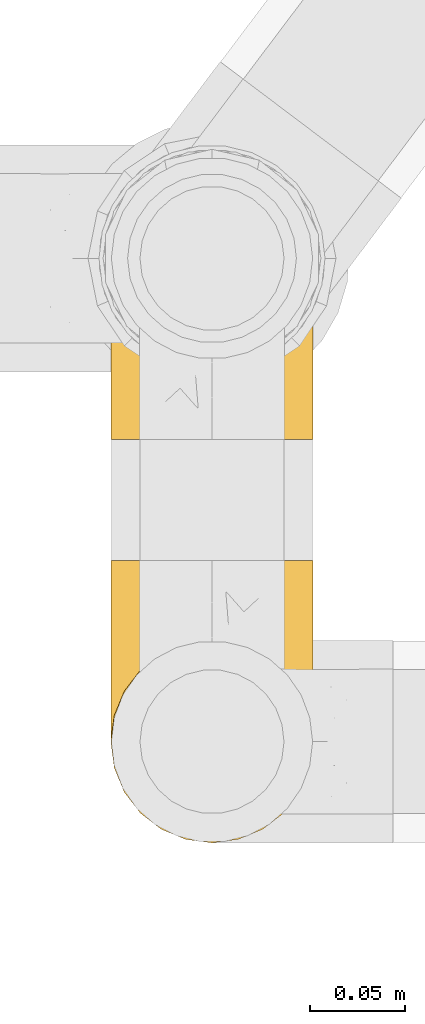
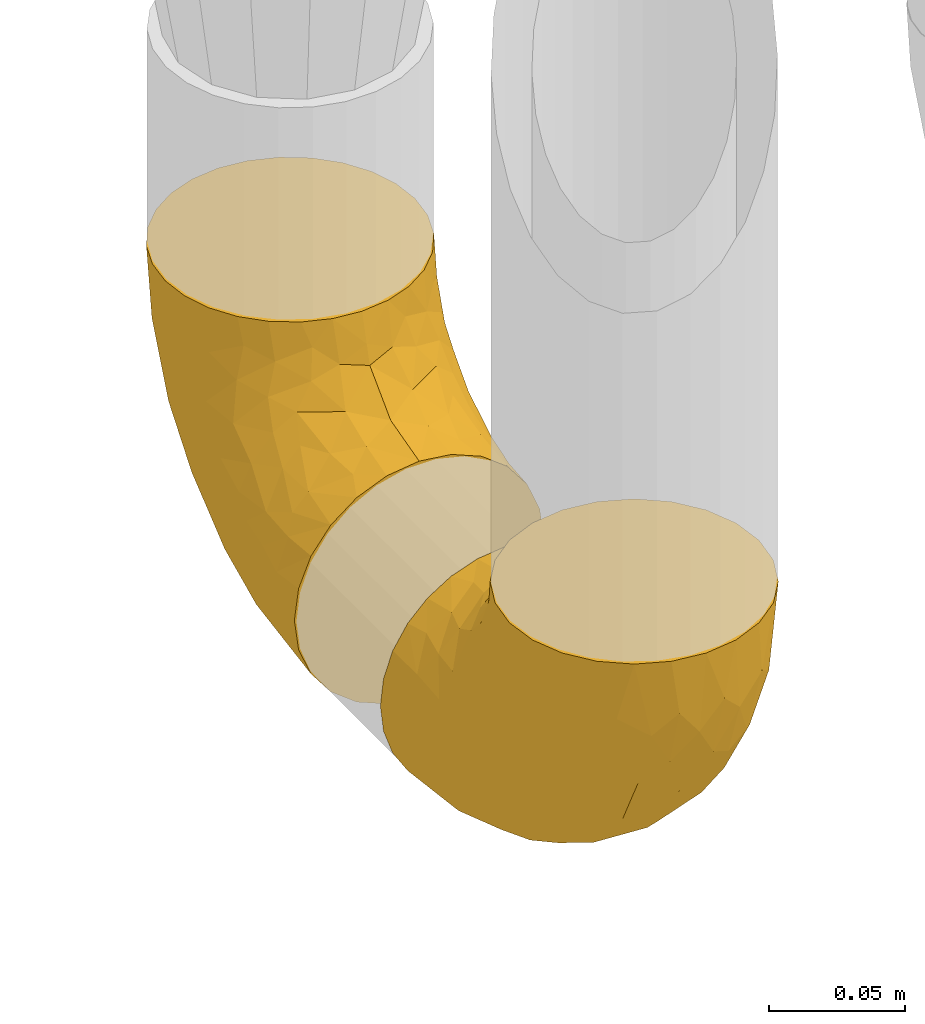
# One storey, part 377 of 827: 2 coverings.
"""IFC2X3 building model written with IfcOpenShell, lengths in millimetres."""

from ifc_helpers import new_model, entity, si_unit, converted_unit, derived_unit, direction, frame, origin, place, context, subcontext, project, spatial, faceted_brep, element, save


model = new_model("IFC2X3")

# Units and contexts
model_context = context("Model", 3, precision=0.01, world=origin(), true_north=direction((6.12303176911189e-17, 1.0)))
body_context = subcontext(model_context, "Body", "Model", "MODEL_VIEW")
ifc_project = project(units=[si_unit("LENGTHUNIT", "METRE", prefix="MILLI"), si_unit("AREAUNIT", "SQUARE_METRE"), si_unit("VOLUMEUNIT", "CUBIC_METRE"), converted_unit("PLANEANGLEUNIT", "DEGREE", entity("IfcRatioMeasure", 0.0174532925199433), si_unit("PLANEANGLEUNIT", "RADIAN"), dimensions=[0, 0, 0, 0, 0, 0, 0]), si_unit("MASSUNIT", "GRAM", prefix="KILO"), derived_unit("MASSDENSITYUNIT", [(si_unit("MASSUNIT", "GRAM", prefix="KILO"), 1), (si_unit("LENGTHUNIT", "METRE"), -3)]), derived_unit("MOMENTOFINERTIAUNIT", [(si_unit("LENGTHUNIT", "METRE"), 4)]), si_unit("TIMEUNIT", "SECOND"), si_unit("FREQUENCYUNIT", "HERTZ"), si_unit("THERMODYNAMICTEMPERATUREUNIT", "DEGREE_CELSIUS"), derived_unit("THERMALTRANSMITTANCEUNIT", [(si_unit("MASSUNIT", "GRAM", prefix="KILO"), 1), (si_unit("THERMODYNAMICTEMPERATUREUNIT", "KELVIN"), -1), (si_unit("TIMEUNIT", "SECOND"), -3)]), derived_unit("VOLUMETRICFLOWRATEUNIT", [(si_unit("LENGTHUNIT", "METRE"), 3), (si_unit("TIMEUNIT", "SECOND"), -1)]), derived_unit("MASSFLOWRATEUNIT", [(si_unit("MASSUNIT", "GRAM", prefix="KILO"), 1), (si_unit("TIMEUNIT", "SECOND"), -1)]), derived_unit("ROTATIONALFREQUENCYUNIT", [(si_unit("TIMEUNIT", "SECOND"), -1)]), si_unit("ELECTRICCURRENTUNIT", "AMPERE"), si_unit("ELECTRICVOLTAGEUNIT", "VOLT"), si_unit("POWERUNIT", "WATT"), si_unit("FORCEUNIT", "NEWTON", prefix="KILO"), si_unit("ILLUMINANCEUNIT", "LUX"), si_unit("LUMINOUSFLUXUNIT", "LUMEN"), si_unit("LUMINOUSINTENSITYUNIT", "CANDELA"), derived_unit("USERDEFINED", [(si_unit("MASSUNIT", "GRAM", prefix="KILO"), -1), (si_unit("LENGTHUNIT", "METRE"), -2), (si_unit("TIMEUNIT", "SECOND"), 3), (si_unit("LUMINOUSFLUXUNIT", "LUMEN"), 1)]), derived_unit("LINEARVELOCITYUNIT", [(si_unit("LENGTHUNIT", "METRE"), 1), (si_unit("TIMEUNIT", "SECOND"), -1)]), si_unit("PRESSUREUNIT", "PASCAL"), derived_unit("USERDEFINED", [(si_unit("LENGTHUNIT", "METRE"), -2), (si_unit("MASSUNIT", "GRAM", prefix="KILO"), 1), (si_unit("TIMEUNIT", "SECOND"), -2)]), derived_unit("LINEARFORCEUNIT", [(si_unit("MASSUNIT", "GRAM", prefix="KILO"), 1), (si_unit("LENGTHUNIT", "METRE"), 1), (si_unit("TIMEUNIT", "SECOND"), -2), (si_unit("LENGTHUNIT", "METRE"), -1)]), derived_unit("PLANARFORCEUNIT", [(si_unit("MASSUNIT", "GRAM", prefix="KILO"), 1), (si_unit("LENGTHUNIT", "METRE"), 1), (si_unit("TIMEUNIT", "SECOND"), -2), (si_unit("LENGTHUNIT", "METRE"), -2)])], contexts=[model_context])

# Site, building, storey
site_placement = place(None, origin())
site = spatial("IfcSite", under=ifc_project, at=site_placement, CompositionType="ELEMENT")
building_placement = place(site_placement, origin())
building = spatial("IfcBuilding", under=site, at=building_placement, CompositionType="ELEMENT")
storey_placement = place(building_placement, frame((0.0, 0.0, 28200.0)))
storey = spatial("IfcBuildingStorey", under=building, at=storey_placement, Name="08", CompositionType="ELEMENT", Elevation=28200.0)

# Coverings
covering_1_placement = place(storey_placement, frame((45438.63, 13582.19, 295.35)))
element("IfcCovering", 1, at=covering_1_placement, inside=storey, Name=":ADSK_", ObjectType=":ADSK_", PredefinedType="INSULATION", context=body_context, shape_type="Brep", body=[
    faceted_brep([(66.44, 149.65, 2.92), (54.65, 149.65, 1.6), (42.84, 149.65, 2.93), (31.62, 149.65, 6.85), (21.56, 149.65, 13.18), (13.16, 149.65, 21.58), (6.84, 149.65, 31.64), (2.92, 149.65, 42.85), (1.6, 149.65, 54.65), (2.93, 149.65, 66.46), (6.85, 149.65, 77.67), (13.18, 149.65, 87.73), (21.58, 149.65, 96.13), (31.64, 149.65, 102.45), (42.85, 149.65, 106.37), (54.65, 149.65, 107.7), (66.46, 149.65, 106.36), (77.67, 149.65, 102.44), (87.73, 149.65, 96.11), (96.13, 149.65, 87.71), (102.45, 149.65, 77.65), (106.37, 149.65, 66.44), (107.7, 149.65, 54.65), (106.36, 149.65, 42.84), (102.44, 149.65, 31.62), (96.11, 149.65, 21.56), (87.71, 149.65, 13.16), (77.65, 149.65, 6.84), (40.91, 105.89, 149.65), (28.12, 100.59, 149.65), (17.13, 92.16, 149.65), (8.7, 81.17, 149.65), (3.4, 68.38, 149.65), (1.6, 54.65, 149.65), (3.4, 40.91, 149.65), (8.7, 28.12, 149.65), (17.13, 17.13, 149.65), (28.12, 8.7, 149.65), (40.91, 3.4, 149.65), (54.65, 1.6, 149.65), (68.38, 3.4, 149.65), (81.17, 8.7, 149.65), (92.16, 17.13, 149.65), (100.59, 28.12, 149.65), (105.89, 40.91, 149.65), (107.7, 54.65, 149.65), (105.89, 68.38, 149.65), (100.59, 81.17, 149.65), (92.16, 92.16, 149.65), (81.17, 100.59, 149.65), (68.38, 105.89, 149.65), (54.65, 107.7, 149.65), (85.53, 14.05, 123.27), (73.42, 9.45, 114.15), (83.77, 22.36, 92.97), (64.22, 4.7, 124.11), (54.65, 6.64, 111.33), (96.72, 81.47, 42.13), (93.36, 56.83, 56.83), (84.47, 64.02, 40.31), (71.37, 34.04, 61.55), (54.65, 21.43, 75.62), (54.65, 44.96, 44.96), (103.47, 49.8, 91.12), (100.91, 35.43, 109.83), (99.1, 42.1, 88.02), (105.43, 43.59, 119.19), (106.79, 57.88, 99.11), (89.81, 91.8, 27.97), (79.59, 88.01, 21.92), (81.29, 115.65, 12.94), (74.01, 18.94, 88.29), (64.14, 12.83, 95.35), (94.75, 24.96, 113.84), (54.65, 111.33, 6.64), (70.74, 113.8, 8.58), (68.3, 60.89, 33.39), (66.05, 86.24, 17.23), (100.73, 65.84, 61.99), (106.78, 124.58, 47.9), (103.6, 121.36, 37.72), (107.7, 72.79, 93.81), (107.7, 66.04, 107.05), (107.7, 59.29, 120.29), (106.07, 73.26, 73.26), (90.59, 121.69, 18.58), (97.43, 109.82, 29.72), (84.51, 40.11, 64.31), (93.3, 36.57, 82.84), (107.7, 93.81, 72.79), (107.7, 83.3, 83.3), (107.7, 136.6, 56.71), (107.7, 120.29, 59.29), (106.79, 99.11, 57.88), (107.7, 107.05, 66.04), (103.47, 91.12, 49.8), (54.65, 75.62, 21.43), (107.7, 56.97, 134.97), (76.99, 126.65, 108.79), (84.28, 116.55, 110.84), (91.11, 120.09, 101.53), (106.26, 76.06, 111.84), (102.6, 83.69, 119.98), (106.08, 71.88, 123.54), (106.56, 66.92, 134.54), (105.36, 110.43, 80.57), (106.74, 121.31, 69.55), (101.59, 81.0, 134.56), (54.65, 113.32, 128.67), (54.65, 111.09, 136.98), (67.71, 109.14, 133.56), (91.36, 95.86, 131.66), (94.33, 99.07, 117.75), (87.1, 106.92, 118.23), (65.84, 131.39, 110.55), (54.65, 136.98, 111.09), (54.65, 128.67, 113.32), (68.92, 117.07, 120.2), (100.82, 96.39, 105.95), (79.83, 106.61, 127.69), (77.13, 103.72, 139.88), (105.9, 92.14, 92.14), (101.53, 107.13, 93.82), (106.72, 98.03, 82.28), (97.75, 88.38, 130.86), (103.08, 130.66, 78.78), (106.39, 135.45, 67.58), (98.1, 123.57, 90.58), (95.02, 137.75, 90.23), (86.9, 133.2, 99.39), (74.42, 138.8, 105.17), (54.65, 120.99, 120.99), (105.28, 84.53, 104.59), (92.87, 108.72, 108.24), (17.93, 95.86, 131.66), (6.22, 130.67, 78.8), (41.58, 109.13, 133.57), (1.6, 93.81, 72.79), (2.57, 98.02, 82.27), (3.94, 110.43, 80.59), (43.46, 131.4, 110.55), (32.32, 126.66, 108.79), (40.38, 117.08, 120.2), (16.44, 108.74, 108.25), (8.47, 96.31, 106.06), (15.01, 99.11, 117.78), (11.21, 123.58, 90.6), (7.78, 107.12, 93.87), (1.6, 72.79, 93.81), (1.6, 66.04, 107.05), (3.04, 76.07, 111.89), (1.6, 56.97, 134.97), (2.73, 66.92, 134.54), (1.6, 120.29, 59.29), (1.6, 107.05, 66.04), (2.55, 121.26, 69.56), (3.98, 84.46, 104.56), (6.69, 83.69, 119.98), (7.7, 81.0, 134.56), (3.21, 71.88, 123.54), (14.28, 137.76, 90.25), (22.42, 133.21, 99.4), (25.02, 116.58, 110.83), (18.18, 120.1, 101.52), (34.89, 138.81, 105.18), (1.6, 136.6, 56.71), (32.17, 103.72, 139.89), (22.23, 106.96, 118.22), (2.91, 135.44, 67.6), (11.54, 88.38, 130.86), (1.6, 83.3, 83.3), (3.38, 92.12, 92.12), (29.46, 106.6, 127.71), (1.6, 59.29, 120.29), (25.52, 22.36, 92.97), (23.76, 14.05, 123.27), (14.54, 24.96, 113.84), (8.38, 35.43, 109.83), (45.07, 4.71, 124.03), (35.87, 9.45, 114.15), (45.14, 11.79, 98.04), (2.5, 57.88, 99.11), (2.51, 124.57, 47.9), (5.68, 121.37, 37.74), (5.82, 91.12, 49.8), (15.93, 56.83, 56.83), (12.54, 81.48, 42.16), (24.81, 64.05, 40.3), (2.5, 99.11, 57.88), (3.22, 73.26, 73.26), (3.86, 43.59, 119.19), (35.85, 19.5, 86.61), (19.47, 91.8, 27.99), (18.68, 121.7, 18.59), (29.68, 88.04, 21.92), (27.95, 123.34, 11.28), (40.99, 60.89, 33.39), (37.92, 34.04, 61.55), (11.85, 109.85, 29.73), (10.19, 42.1, 88.01), (8.55, 65.78, 62.08), (38.53, 113.81, 8.58), (15.99, 36.57, 82.84), (24.79, 40.12, 64.3), (5.82, 49.8, 91.12), (40.56, 86.08, 18.05)], [[[0, 1, 2, 3, 4, 5, 6, 7, 8, 9, 10, 11, 12, 13, 14, 15, 16, 17, 18, 19, 20, 21, 22, 23, 24, 25, 26, 27]], [[28, 29, 30, 31, 32, 33, 34, 35, 36, 37, 38, 39, 40, 41, 42, 43, 44, 45, 46, 47, 48, 49, 50, 51]], [[52, 53, 54]], [[55, 39, 56]], [[57, 58, 59]], [[60, 61, 62]], [[63, 64, 65]], [[66, 63, 67]], [[68, 69, 70]], [[53, 71, 54]], [[41, 40, 53]], [[53, 72, 71]], [[73, 42, 52]], [[42, 41, 52]], [[74, 0, 75]], [[69, 76, 77]], [[43, 73, 64]], [[45, 44, 66]], [[57, 78, 58]], [[23, 79, 80]], [[67, 81, 82, 83]], [[67, 84, 81]], [[24, 23, 80]], [[25, 85, 26]], [[86, 85, 25]], [[42, 73, 43]], [[0, 27, 75]], [[25, 24, 86]], [[70, 26, 85]], [[0, 74, 1]], [[68, 85, 86]], [[66, 64, 63]], [[60, 59, 87]], [[54, 87, 88]], [[76, 60, 62]], [[84, 89, 90, 81]], [[79, 22, 91, 92]], [[77, 74, 75]], [[93, 92, 94, 89]], [[80, 86, 24]], [[40, 55, 53]], [[76, 59, 60]], [[93, 84, 95]], [[76, 62, 96]], [[55, 72, 53]], [[70, 27, 26]], [[75, 70, 69]], [[78, 84, 63]], [[93, 79, 92]], [[95, 86, 80]], [[77, 76, 96]], [[59, 69, 68]], [[57, 68, 86]], [[68, 57, 59]], [[59, 58, 87]], [[76, 69, 59]], [[88, 87, 58]], [[87, 54, 71]], [[86, 95, 57]], [[78, 57, 95]], [[84, 78, 95]], [[78, 63, 65]], [[58, 78, 65]], [[54, 88, 73]], [[84, 93, 89]], [[79, 95, 80]], [[79, 93, 95]], [[22, 79, 23]], [[66, 83, 97, 45]], [[84, 67, 63]], [[83, 66, 67]], [[64, 44, 43]], [[64, 66, 44]], [[65, 73, 88]], [[53, 52, 41]], [[73, 52, 54]], [[73, 65, 64]], [[65, 88, 58]], [[39, 55, 40]], [[72, 55, 56]], [[56, 61, 72]], [[60, 72, 61]], [[72, 60, 71]], [[87, 71, 60]], [[27, 70, 75]], [[68, 70, 85]], [[74, 77, 96]], [[69, 77, 75]], [[98, 99, 100]], [[46, 45, 97]], [[101, 102, 103]], [[103, 104, 83]], [[105, 94, 106]], [[107, 103, 102]], [[108, 109, 51, 110]], [[111, 112, 113]], [[114, 115, 116]], [[47, 104, 107]], [[110, 117, 108]], [[49, 48, 111]], [[102, 118, 112]], [[119, 120, 111]], [[50, 49, 120]], [[121, 122, 118]], [[105, 123, 89]], [[124, 48, 107]], [[20, 19, 125]], [[121, 81, 90]], [[117, 119, 99]], [[21, 20, 126]], [[22, 21, 91]], [[105, 125, 127]], [[110, 51, 50]], [[19, 128, 125]], [[16, 15, 115]], [[129, 98, 100]], [[126, 91, 21]], [[128, 129, 127]], [[122, 123, 105]], [[114, 117, 98]], [[17, 16, 130]], [[18, 128, 19]], [[129, 18, 17]], [[125, 106, 126]], [[115, 114, 16]], [[130, 129, 17]], [[114, 98, 130]], [[117, 116, 131, 108]], [[99, 119, 113]], [[122, 121, 123]], [[92, 126, 106]], [[105, 127, 122]], [[132, 121, 118]], [[114, 130, 16]], [[129, 130, 98]], [[50, 120, 110]], [[129, 128, 18]], [[125, 128, 127]], [[125, 126, 20]], [[91, 126, 92]], [[105, 89, 94]], [[105, 106, 125]], [[94, 92, 106]], [[100, 122, 127]], [[118, 122, 133]], [[112, 118, 133]], [[132, 118, 102]], [[132, 102, 101]], [[81, 121, 132]], [[82, 103, 83]], [[132, 101, 81]], [[104, 47, 46]], [[124, 107, 102]], [[48, 47, 107]], [[113, 112, 133]], [[112, 111, 124]], [[99, 113, 133]], [[111, 113, 119]], [[99, 133, 100]], [[117, 99, 98]], [[122, 100, 133]], [[127, 129, 100]], [[103, 82, 101]], [[81, 101, 82]], [[112, 124, 102]], [[48, 124, 111]], [[104, 103, 107]], [[46, 97, 104]], [[111, 120, 49]], [[83, 104, 97]], [[110, 120, 119]], [[117, 110, 119]], [[116, 117, 114]], [[89, 123, 90]], [[90, 123, 121]], [[30, 29, 134]], [[11, 10, 135]], [[51, 109, 108, 136]], [[137, 138, 139]], [[140, 141, 142]], [[143, 144, 145]], [[146, 139, 147]], [[148, 149, 150]], [[151, 32, 152]], [[153, 154, 155]], [[156, 150, 157]], [[158, 157, 159]], [[108, 142, 136]], [[31, 158, 152]], [[160, 161, 12]], [[162, 163, 143]], [[140, 142, 116]], [[142, 141, 162]], [[14, 164, 140]], [[14, 140, 115]], [[9, 8, 165]], [[160, 12, 11]], [[141, 164, 161]], [[13, 12, 161]], [[14, 115, 15]], [[28, 166, 29]], [[135, 139, 146]], [[141, 163, 162]], [[135, 146, 160]], [[143, 167, 162]], [[29, 166, 134]], [[116, 142, 108, 131]], [[165, 153, 168]], [[10, 9, 168]], [[168, 135, 10]], [[138, 147, 139]], [[158, 169, 157]], [[14, 13, 164]], [[116, 115, 140]], [[145, 167, 143]], [[135, 160, 11]], [[168, 153, 155]], [[138, 170, 171]], [[157, 144, 156]], [[147, 144, 143]], [[161, 164, 13]], [[140, 164, 141]], [[142, 172, 136]], [[136, 172, 166]], [[161, 160, 146]], [[165, 168, 9]], [[155, 139, 135]], [[139, 154, 137]], [[168, 155, 135]], [[139, 155, 154]], [[144, 147, 171]], [[163, 147, 143]], [[156, 144, 171]], [[157, 169, 145]], [[171, 148, 156]], [[173, 159, 149]], [[159, 157, 150]], [[152, 159, 173]], [[159, 152, 158]], [[31, 30, 158]], [[169, 30, 134]], [[157, 145, 144]], [[167, 134, 172]], [[134, 167, 145]], [[172, 142, 162]], [[162, 167, 172]], [[163, 141, 161]], [[161, 146, 163]], [[147, 163, 146]], [[148, 150, 156]], [[149, 159, 150]], [[30, 169, 158]], [[145, 169, 134]], [[151, 33, 32]], [[31, 152, 32]], [[152, 173, 151]], [[28, 51, 136]], [[134, 166, 172]], [[28, 136, 166]], [[147, 138, 171]], [[170, 138, 137]], [[170, 148, 171]], [[174, 175, 176]], [[35, 34, 177]], [[178, 179, 180]], [[181, 173, 149, 148]], [[182, 183, 184]], [[185, 186, 187]], [[188, 189, 137]], [[190, 33, 151, 173]], [[191, 179, 174]], [[34, 190, 177]], [[39, 38, 178]], [[192, 193, 194]], [[4, 3, 195]], [[175, 179, 37]], [[38, 37, 179]], [[35, 176, 36]], [[196, 62, 197]], [[181, 190, 173]], [[37, 36, 175]], [[183, 6, 198]], [[189, 148, 170, 137]], [[185, 199, 200]], [[3, 2, 201]], [[202, 185, 203]], [[8, 7, 182]], [[200, 184, 186]], [[183, 7, 6]], [[181, 189, 204]], [[200, 189, 184]], [[5, 198, 6]], [[187, 203, 185]], [[195, 3, 201]], [[205, 196, 194]], [[62, 61, 197]], [[186, 198, 192]], [[180, 179, 191]], [[2, 1, 74]], [[198, 193, 192]], [[193, 5, 4]], [[194, 193, 195]], [[2, 74, 201]], [[5, 193, 198]], [[205, 74, 96]], [[188, 137, 154, 153]], [[62, 196, 96]], [[56, 178, 180]], [[198, 184, 183]], [[184, 188, 182]], [[203, 197, 191]], [[205, 194, 201]], [[187, 192, 194]], [[192, 187, 186]], [[194, 196, 187]], [[197, 187, 196]], [[197, 203, 187]], [[202, 174, 176]], [[200, 186, 185]], [[184, 198, 186]], [[199, 185, 202]], [[189, 200, 204]], [[174, 202, 203]], [[176, 177, 199]], [[189, 181, 148]], [[190, 181, 204]], [[190, 204, 177]], [[190, 34, 33]], [[188, 153, 182]], [[189, 188, 184]], [[182, 153, 165, 8]], [[183, 182, 7]], [[199, 177, 204]], [[35, 177, 176]], [[176, 175, 36]], [[179, 175, 174]], [[200, 199, 204]], [[176, 199, 202]], [[203, 191, 174]], [[180, 197, 61]], [[197, 180, 191]], [[61, 56, 180]], [[39, 178, 56]], [[38, 179, 178]], [[194, 195, 201]], [[4, 195, 193]], [[74, 205, 201]], [[96, 196, 205]]]),
])
covering_2_placement = place(storey_placement, frame((45438.63, 13793.58, 295.35)))
element("IfcCovering", 2, at=covering_2_placement, inside=storey, Name=":ADSK_", ObjectType=":ADSK_", PredefinedType="INSULATION", context=body_context, shape_type="Brep", body=[
    faceted_brep([(66.44, 148.32, 149.65), (54.65, 149.65, 149.65), (42.84, 148.31, 149.65), (31.62, 144.39, 149.65), (21.56, 138.06, 149.65), (13.16, 129.66, 149.65), (6.84, 119.6, 149.65), (2.92, 108.39, 149.65), (1.6, 96.6, 149.65), (2.93, 84.79, 149.65), (6.85, 73.57, 149.65), (13.18, 63.51, 149.65), (21.58, 55.11, 149.65), (31.64, 48.79, 149.65), (42.85, 44.87, 149.65), (54.65, 43.55, 149.65), (66.46, 44.88, 149.65), (77.67, 48.8, 149.65), (87.73, 55.13, 149.65), (96.13, 63.53, 149.65), (102.45, 73.59, 149.65), (106.37, 84.8, 149.65), (107.7, 96.6, 149.65), (106.36, 108.41, 149.65), (102.44, 119.62, 149.65), (96.11, 129.68, 149.65), (87.71, 138.08, 149.65), (77.65, 144.4, 149.65), (40.91, 1.6, 105.89), (28.12, 1.6, 100.59), (17.13, 1.6, 92.16), (8.7, 1.6, 81.17), (3.4, 1.6, 68.38), (1.6, 1.6, 54.65), (3.4, 1.6, 40.91), (8.7, 1.6, 28.12), (17.13, 1.6, 17.13), (28.12, 1.6, 8.7), (40.91, 1.6, 3.4), (54.65, 1.6, 1.6), (68.38, 1.6, 3.4), (81.17, 1.6, 8.7), (92.16, 1.6, 17.13), (100.59, 1.6, 28.12), (105.89, 1.6, 40.91), (107.7, 1.6, 54.65), (105.89, 1.6, 68.38), (100.59, 1.6, 81.17), (92.16, 1.6, 92.16), (81.17, 1.6, 100.59), (68.38, 1.6, 105.89), (54.65, 1.6, 107.7), (85.53, 27.97, 14.05), (73.42, 37.09, 9.45), (83.77, 58.27, 22.36), (64.22, 27.13, 4.7), (54.65, 39.91, 6.64), (96.72, 109.11, 81.47), (93.36, 94.41, 56.83), (84.47, 110.94, 64.02), (71.37, 89.69, 34.04), (54.65, 75.62, 21.43), (54.65, 106.28, 44.96), (103.47, 60.12, 49.8), (100.91, 41.41, 35.43), (99.1, 63.22, 42.1), (105.43, 32.05, 43.59), (106.79, 52.13, 57.88), (89.81, 123.27, 91.8), (79.59, 129.32, 88.01), (81.29, 138.3, 115.65), (74.01, 62.95, 18.94), (64.14, 55.89, 12.83), (94.75, 37.4, 24.96), (54.65, 144.6, 111.33), (70.74, 142.66, 113.8), (68.3, 117.85, 60.89), (66.05, 134.01, 86.24), (100.73, 89.25, 65.84), (106.78, 103.34, 124.58), (103.6, 113.52, 121.36), (107.7, 57.43, 72.79), (107.7, 44.19, 66.04), (107.7, 30.95, 59.29), (106.07, 77.98, 73.26), (90.59, 132.66, 121.69), (97.43, 121.52, 109.82), (84.51, 86.93, 40.11), (93.3, 68.4, 36.57), (107.7, 78.45, 93.81), (107.7, 67.94, 83.3), (107.7, 94.53, 136.6), (107.7, 91.95, 120.29), (106.79, 93.36, 99.11), (107.7, 85.2, 107.05), (103.47, 101.45, 91.12), (54.65, 129.81, 75.62), (107.7, 16.27, 56.97), (76.99, 42.46, 126.65), (84.28, 40.4, 116.55), (91.11, 49.71, 120.09), (106.26, 39.4, 76.06), (102.6, 31.26, 83.69), (106.08, 27.7, 71.88), (106.56, 16.7, 66.92), (105.36, 70.67, 110.43), (106.74, 81.69, 121.31), (101.59, 16.68, 81.0), (54.65, 22.57, 113.32), (54.65, 14.26, 111.09), (67.71, 17.68, 109.14), (91.36, 19.58, 95.86), (94.33, 33.49, 99.07), (87.1, 33.01, 106.92), (65.84, 40.69, 131.39), (54.65, 40.15, 136.98), (54.65, 37.93, 128.67), (68.92, 31.04, 117.07), (100.82, 45.29, 96.39), (79.83, 23.55, 106.61), (77.13, 11.36, 103.72), (105.9, 59.1, 92.14), (101.53, 57.42, 107.13), (106.72, 68.96, 98.03), (97.75, 20.38, 88.38), (103.08, 72.46, 130.66), (106.39, 83.66, 135.45), (98.1, 60.66, 123.57), (95.02, 61.01, 137.75), (86.9, 51.85, 133.2), (74.42, 46.07, 138.8), (54.65, 30.25, 120.99), (105.28, 46.65, 84.53), (92.87, 43.0, 108.72), (17.93, 19.58, 95.86), (6.22, 72.44, 130.67), (41.58, 17.67, 109.13), (1.6, 78.45, 93.81), (2.57, 68.97, 98.02), (3.94, 70.65, 110.43), (43.46, 40.69, 131.4), (32.32, 42.45, 126.66), (40.38, 31.04, 117.08), (16.44, 42.99, 108.74), (8.47, 45.18, 96.31), (15.01, 33.46, 99.11), (11.21, 60.64, 123.58), (7.78, 57.37, 107.12), (1.6, 57.43, 72.79), (1.6, 44.19, 66.04), (3.04, 39.35, 76.07), (1.6, 16.27, 56.97), (2.73, 16.7, 66.92), (1.6, 91.95, 120.29), (1.6, 85.2, 107.05), (2.55, 81.68, 121.26), (3.98, 46.68, 84.46), (6.69, 31.26, 83.69), (7.7, 16.68, 81.0), (3.21, 27.7, 71.88), (14.28, 60.99, 137.76), (22.42, 51.84, 133.21), (25.02, 40.41, 116.58), (18.18, 49.72, 120.1), (34.89, 46.06, 138.81), (1.6, 94.53, 136.6), (32.17, 11.35, 103.72), (22.23, 33.02, 106.96), (2.91, 83.65, 135.44), (11.54, 20.38, 88.38), (1.6, 67.94, 83.3), (29.46, 23.53, 106.6), (3.38, 59.12, 92.12), (1.6, 30.95, 59.29), (25.52, 58.27, 22.36), (23.76, 27.97, 14.05), (14.54, 37.4, 24.96), (8.38, 41.41, 35.43), (45.07, 27.21, 4.71), (35.87, 37.09, 9.45), (45.14, 53.2, 11.79), (2.5, 52.13, 57.88), (2.51, 103.34, 124.57), (5.68, 113.5, 121.37), (5.82, 101.45, 91.12), (15.93, 94.41, 56.83), (12.54, 109.08, 81.48), (24.81, 110.95, 64.05), (2.5, 93.36, 99.11), (3.22, 77.98, 73.26), (3.86, 32.05, 43.59), (35.85, 64.63, 19.5), (19.47, 123.25, 91.8), (18.68, 132.65, 121.7), (29.68, 129.32, 88.04), (27.95, 139.96, 123.34), (40.99, 117.85, 60.89), (37.92, 89.69, 34.04), (11.85, 121.51, 109.85), (10.19, 63.23, 42.1), (8.55, 89.17, 65.78), (38.53, 142.66, 113.81), (15.99, 68.4, 36.57), (24.79, 86.94, 40.12), (5.82, 60.12, 49.8), (40.56, 133.2, 86.08)], [[[0, 1, 2, 3, 4, 5, 6, 7, 8, 9, 10, 11, 12, 13, 14, 15, 16, 17, 18, 19, 20, 21, 22, 23, 24, 25, 26, 27]], [[28, 29, 30, 31, 32, 33, 34, 35, 36, 37, 38, 39, 40, 41, 42, 43, 44, 45, 46, 47, 48, 49, 50, 51]], [[52, 53, 54]], [[55, 39, 56]], [[57, 58, 59]], [[60, 61, 62]], [[63, 64, 65]], [[66, 63, 67]], [[68, 69, 70]], [[53, 71, 54]], [[41, 40, 53]], [[53, 72, 71]], [[73, 42, 52]], [[42, 41, 52]], [[74, 0, 75]], [[69, 76, 77]], [[43, 73, 64]], [[45, 44, 66]], [[57, 78, 58]], [[23, 79, 80]], [[67, 81, 82, 83]], [[67, 84, 81]], [[24, 23, 80]], [[25, 85, 26]], [[86, 85, 25]], [[42, 73, 43]], [[0, 27, 75]], [[25, 24, 86]], [[70, 26, 85]], [[0, 74, 1]], [[68, 85, 86]], [[66, 64, 63]], [[60, 59, 87]], [[54, 87, 88]], [[76, 60, 62]], [[84, 89, 90, 81]], [[79, 22, 91, 92]], [[77, 74, 75]], [[93, 92, 94, 89]], [[80, 86, 24]], [[40, 55, 53]], [[76, 59, 60]], [[93, 84, 95]], [[76, 62, 96]], [[55, 72, 53]], [[70, 27, 26]], [[75, 70, 69]], [[78, 84, 63]], [[93, 79, 92]], [[95, 86, 80]], [[77, 76, 96]], [[59, 69, 68]], [[57, 68, 86]], [[68, 57, 59]], [[59, 58, 87]], [[76, 69, 59]], [[88, 87, 58]], [[87, 54, 71]], [[86, 95, 57]], [[78, 57, 95]], [[84, 78, 95]], [[78, 63, 65]], [[58, 78, 65]], [[54, 88, 73]], [[84, 93, 89]], [[79, 95, 80]], [[79, 93, 95]], [[22, 79, 23]], [[66, 83, 97, 45]], [[84, 67, 63]], [[83, 66, 67]], [[64, 44, 43]], [[64, 66, 44]], [[65, 73, 88]], [[53, 52, 41]], [[73, 52, 54]], [[73, 65, 64]], [[65, 88, 58]], [[39, 55, 40]], [[72, 55, 56]], [[56, 61, 72]], [[60, 72, 61]], [[72, 60, 71]], [[87, 71, 60]], [[27, 70, 75]], [[68, 70, 85]], [[74, 77, 96]], [[69, 77, 75]], [[98, 99, 100]], [[46, 45, 97]], [[101, 102, 103]], [[103, 104, 83]], [[105, 94, 106]], [[107, 103, 102]], [[108, 109, 51, 110]], [[111, 112, 113]], [[114, 115, 116]], [[47, 104, 107]], [[110, 117, 108]], [[49, 48, 111]], [[102, 118, 112]], [[119, 120, 111]], [[50, 49, 120]], [[121, 122, 118]], [[105, 123, 89]], [[124, 48, 107]], [[20, 19, 125]], [[121, 81, 90]], [[117, 119, 99]], [[21, 20, 126]], [[22, 21, 91]], [[105, 125, 127]], [[110, 51, 50]], [[19, 128, 125]], [[16, 15, 115]], [[129, 98, 100]], [[126, 91, 21]], [[128, 129, 127]], [[122, 123, 105]], [[114, 117, 98]], [[17, 16, 130]], [[18, 128, 19]], [[129, 18, 17]], [[125, 106, 126]], [[115, 114, 16]], [[130, 129, 17]], [[114, 98, 130]], [[117, 116, 131, 108]], [[99, 119, 113]], [[122, 121, 123]], [[92, 126, 106]], [[105, 127, 122]], [[132, 121, 118]], [[114, 130, 16]], [[129, 130, 98]], [[50, 120, 110]], [[129, 128, 18]], [[125, 128, 127]], [[125, 126, 20]], [[91, 126, 92]], [[105, 89, 94]], [[105, 106, 125]], [[94, 92, 106]], [[100, 122, 127]], [[118, 122, 133]], [[112, 118, 133]], [[132, 118, 102]], [[132, 102, 101]], [[81, 121, 132]], [[82, 103, 83]], [[132, 101, 81]], [[104, 47, 46]], [[124, 107, 102]], [[48, 47, 107]], [[113, 112, 133]], [[112, 111, 124]], [[99, 113, 133]], [[111, 113, 119]], [[99, 133, 100]], [[117, 99, 98]], [[122, 100, 133]], [[127, 129, 100]], [[103, 82, 101]], [[81, 101, 82]], [[112, 124, 102]], [[48, 124, 111]], [[104, 103, 107]], [[46, 97, 104]], [[111, 120, 49]], [[83, 104, 97]], [[110, 120, 119]], [[117, 110, 119]], [[116, 117, 114]], [[89, 123, 90]], [[90, 123, 121]], [[30, 29, 134]], [[11, 10, 135]], [[51, 109, 108, 136]], [[137, 138, 139]], [[140, 141, 142]], [[143, 144, 145]], [[146, 139, 147]], [[148, 149, 150]], [[151, 32, 152]], [[153, 154, 155]], [[156, 150, 157]], [[158, 157, 159]], [[108, 142, 136]], [[31, 158, 152]], [[160, 161, 12]], [[162, 163, 143]], [[140, 142, 116]], [[142, 141, 162]], [[14, 164, 140]], [[14, 140, 115]], [[9, 8, 165]], [[160, 12, 11]], [[141, 164, 161]], [[13, 12, 161]], [[14, 115, 15]], [[28, 166, 29]], [[135, 139, 146]], [[141, 163, 162]], [[135, 146, 160]], [[143, 167, 162]], [[29, 166, 134]], [[116, 142, 108, 131]], [[165, 153, 168]], [[10, 9, 168]], [[168, 135, 10]], [[138, 147, 139]], [[158, 169, 157]], [[14, 13, 164]], [[116, 115, 140]], [[145, 167, 143]], [[135, 160, 11]], [[168, 153, 155]], [[138, 137, 170]], [[157, 144, 156]], [[147, 144, 143]], [[161, 164, 13]], [[140, 164, 141]], [[142, 171, 136]], [[136, 171, 166]], [[161, 160, 146]], [[165, 168, 9]], [[155, 139, 135]], [[139, 154, 137]], [[168, 155, 135]], [[139, 155, 154]], [[144, 147, 172]], [[163, 147, 143]], [[156, 144, 172]], [[157, 169, 145]], [[172, 148, 156]], [[173, 159, 149]], [[159, 157, 150]], [[152, 159, 173]], [[159, 152, 158]], [[31, 30, 158]], [[169, 30, 134]], [[157, 145, 144]], [[167, 134, 171]], [[134, 167, 145]], [[171, 142, 162]], [[162, 167, 171]], [[163, 141, 161]], [[161, 146, 163]], [[147, 163, 146]], [[148, 150, 156]], [[149, 159, 150]], [[30, 169, 158]], [[145, 169, 134]], [[151, 33, 32]], [[31, 152, 32]], [[152, 173, 151]], [[28, 51, 136]], [[134, 166, 171]], [[28, 136, 166]], [[138, 170, 172]], [[147, 138, 172]], [[148, 172, 170]], [[174, 175, 176]], [[35, 34, 177]], [[178, 179, 180]], [[181, 173, 149, 148]], [[182, 183, 184]], [[185, 186, 187]], [[188, 189, 137]], [[190, 33, 151, 173]], [[191, 179, 174]], [[34, 190, 177]], [[39, 38, 178]], [[192, 193, 194]], [[4, 3, 195]], [[175, 179, 37]], [[38, 37, 179]], [[35, 176, 36]], [[196, 62, 197]], [[181, 190, 173]], [[37, 36, 175]], [[183, 6, 198]], [[189, 148, 170, 137]], [[185, 199, 200]], [[3, 2, 201]], [[202, 185, 203]], [[8, 7, 182]], [[200, 184, 186]], [[183, 7, 6]], [[181, 189, 204]], [[200, 189, 184]], [[5, 198, 6]], [[187, 203, 185]], [[195, 3, 201]], [[205, 196, 194]], [[62, 61, 197]], [[186, 198, 192]], [[180, 179, 191]], [[2, 1, 74]], [[198, 193, 192]], [[193, 5, 4]], [[194, 193, 195]], [[2, 74, 201]], [[5, 193, 198]], [[205, 74, 96]], [[188, 137, 154, 153]], [[62, 196, 96]], [[56, 178, 180]], [[198, 184, 183]], [[184, 188, 182]], [[203, 197, 191]], [[205, 194, 201]], [[187, 192, 194]], [[192, 187, 186]], [[194, 196, 187]], [[197, 187, 196]], [[197, 203, 187]], [[202, 174, 176]], [[200, 186, 185]], [[184, 198, 186]], [[199, 185, 202]], [[189, 200, 204]], [[174, 202, 203]], [[176, 177, 199]], [[189, 181, 148]], [[190, 181, 204]], [[190, 204, 177]], [[190, 34, 33]], [[188, 153, 182]], [[189, 188, 184]], [[182, 153, 165, 8]], [[183, 182, 7]], [[199, 177, 204]], [[35, 177, 176]], [[176, 175, 36]], [[179, 175, 174]], [[200, 199, 204]], [[176, 199, 202]], [[203, 191, 174]], [[180, 197, 61]], [[197, 180, 191]], [[61, 56, 180]], [[39, 178, 56]], [[38, 179, 178]], [[194, 195, 201]], [[4, 195, 193]], [[74, 205, 201]], [[96, 196, 205]]]),
])

save(model, "model.ifc")
